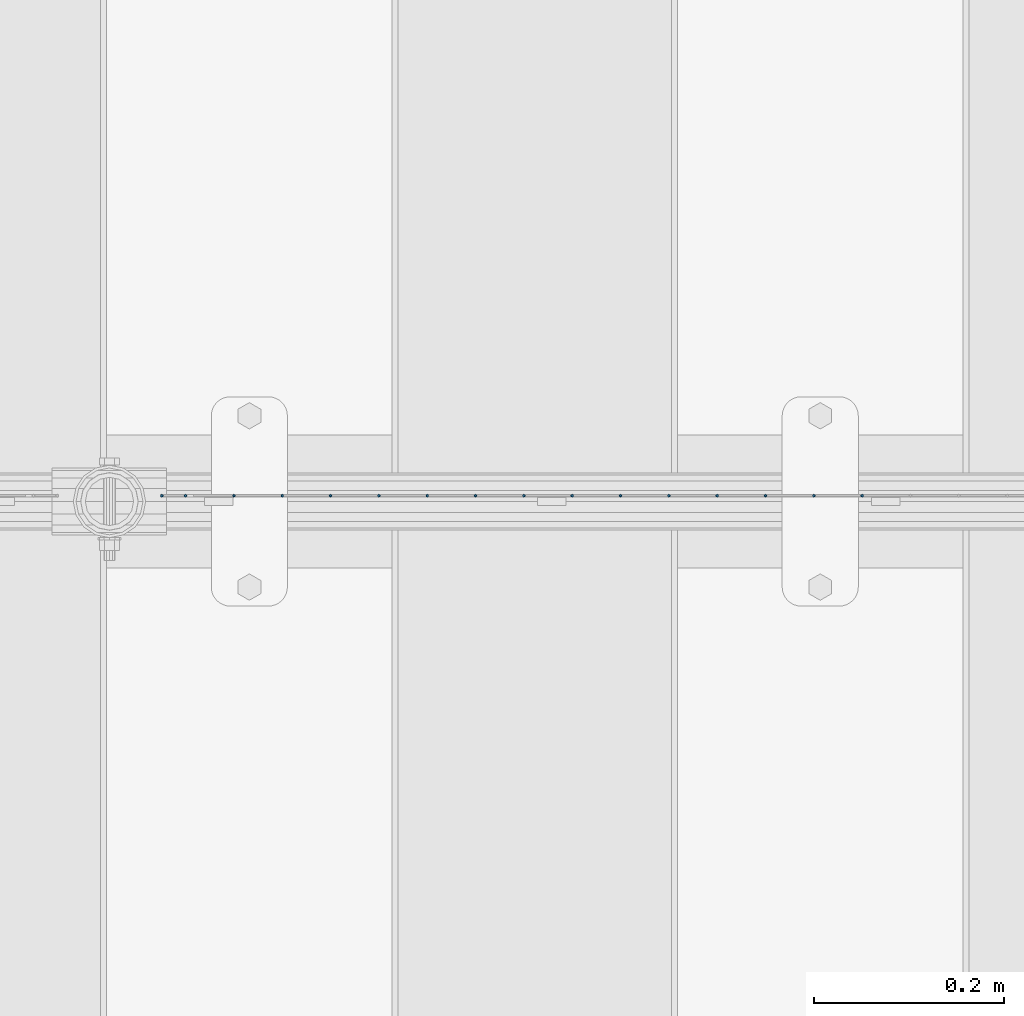
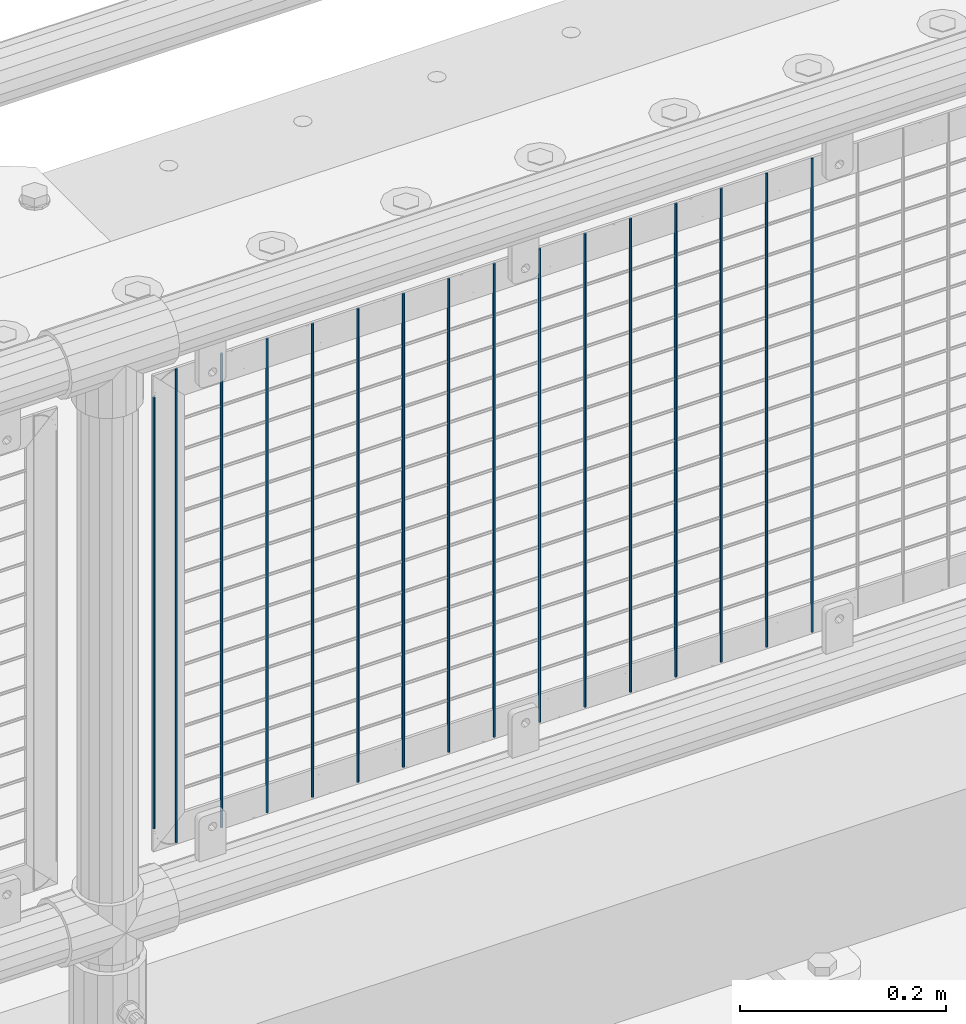
# One storey, part 77 of 242: 16 columns.
"""IFC2X3 building model written with IfcOpenShell, lengths in millimetres."""

from ifc_helpers import new_model, si_unit, frame, origin_with_axes, place, context, subcontext, project, spatial, faceted_brep, material, type_object, element, save


model = new_model("IFC2X3")

# Units and contexts
model_context = context("Model", 3, precision=1e-05, world=origin_with_axes())
body_context = subcontext(model_context, "Body", "Model", "MODEL_VIEW")
ifc_project = project(units=[si_unit("LENGTHUNIT", "METRE", prefix="MILLI"), si_unit("AREAUNIT", "SQUARE_METRE"), si_unit("VOLUMEUNIT", "CUBIC_METRE"), si_unit("MASSUNIT", "GRAM", prefix="KILO"), si_unit("TIMEUNIT", "SECOND"), si_unit("PLANEANGLEUNIT", "RADIAN"), si_unit("SOLIDANGLEUNIT", "STERADIAN"), si_unit("THERMODYNAMICTEMPERATUREUNIT", "DEGREE_CELSIUS"), si_unit("LUMINOUSINTENSITYUNIT", "LUMEN")], contexts=[model_context])

# Site, building, storey
site_placement = place(None, origin_with_axes())
site = spatial("IfcSite", under=ifc_project, at=site_placement, CompositionType="ELEMENT")
building_placement = place(site_placement, origin_with_axes())
building = spatial("IfcBuilding", under=site, at=building_placement, Name="Standard", CompositionType="ELEMENT")
storey_placement = place(building_placement, origin_with_axes())
storey = spatial("IfcBuildingStorey", under=building, at=storey_placement, Name="Undefined", CompositionType="ELEMENT", Elevation=0.0)

# Columns
ifc_material = material(Name="Misc_Undefined")
column_type = type_object("IfcColumnType", Name="D3", PredefinedType="NOTDEFINED")
for number, where, z_axis, x_axis in (
    (1, (-34505.898, -19329.5, 353.02), (-1.0, 0.0, 0.0), (0.0, 0.0, 1.0)),
    (2, (-34556.691, -19329.5, 353.02), (-1.0, 0.0, 0.0), (0.0, 0.0, 1.0)),
    (3, (-34607.484, -19329.5, 353.02), (-1.0, 0.0, 0.0), (0.0, 0.0, 1.0)),
    (4, (-34658.277, -19329.5, 353.02), (-1.0, 0.0, 0.0), (0.0, 0.0, 1.0)),
    (5, (-34709.07, -19329.5, 353.02), (-1.0, 0.0, 0.0), (0.0, 0.0, 1.0)),
    (6, (-34759.863, -19329.5, 353.02), (-1.0, 0.0, 0.0), (0.0, 0.0, 1.0)),
    (7, (-34810.656, -19329.5, 353.02), (-1.0, 0.0, 0.0), (0.0, 0.0, 1.0)),
    (8, (-34861.449, -19329.5, 353.02), (-1.0, 0.0, 0.0), (0.0, 0.0, 1.0)),
    (9, (-34912.242, -19329.5, 353.02), (-1.0, 0.0, 0.0), (0.0, 0.0, 1.0)),
    (10, (-34963.035, -19329.5, 353.02), (-1.0, 0.0, 0.0), (0.0, 0.0, 1.0)),
    (11, (-35013.828, -19329.5, 353.02), (-1.0, 0.0, 0.0), (0.0, 0.0, 1.0)),
    (12, (-35064.621, -19329.5, 353.02), (-1.0, 0.0, 0.0), (0.0, 0.0, 1.0)),
    (13, (-35115.414, -19329.5, 353.02), (-1.0, 0.0, 0.0), (0.0, 0.0, 1.0)),
    (14, (-35166.207, -19329.5, 353.02), (-1.0, 0.0, 0.0), (0.0, 0.0, 1.0)),
):
    element("IfcColumn", number, at=place(storey_placement, frame(where, z_axis=z_axis, x_axis=x_axis)), inside=storey, type_object=column_type, material=ifc_material, ObjectType="D3", context=body_context, shape_type="Brep", body=[
        faceted_brep([(0.0, -1.50000000000364, 0.0), (-3.63797880709171e-12, -0.750000000003638, -1.29903810567669), (560.0, -0.75, -1.29903810567703), (560.0, -1.5, 0.0), (0.0, 0.749999999996362, -1.29903810567669), (560.0, 0.75, -1.29903810567703), (-3.63797880709171e-12, 1.49999999999636, 0.0), (560.0, 1.5, 0.0), (0.0, 0.749999999996362, 1.29903810567669), (560.0, 0.75, 1.29903810567703), (-3.63797880709171e-12, -0.750000000003638, 1.29903810567669), (560.0, -0.75, 1.29903810567703)], [[[0, 1, 2, 3]], [[1, 4, 5, 2]], [[4, 6, 7, 5]], [[6, 8, 9, 7]], [[8, 10, 11, 9]], [[10, 0, 3, 11]], [[5, 7, 9, 11, 3, 2]], [[10, 8, 6, 4, 1, 0]]]),
    ])
column_1_placement = place(storey_placement, frame((-35242.0, -19329.5, 378.02), z_axis=(-1.0, 0.0, 0.0), x_axis=(0.0, 0.0, 1.0)))
element("IfcColumn", 15, at=column_1_placement, inside=storey, type_object=column_type, material=ifc_material, ObjectType="D3", context=body_context, shape_type="Brep", body=[
    faceted_brep([(0.0, -1.50000000000364, 0.0), (-3.63797880709171e-12, -0.750000000003638, -1.29903810567669), (510.0, -0.75, -1.29903810567703), (510.0, -1.5, 0.0), (0.0, 0.749999999996362, -1.29903810567669), (510.0, 0.75, -1.29903810567703), (-3.63797880709171e-12, 1.49999999999636, 0.0), (510.0, 1.5, 0.0), (0.0, 0.749999999996362, 1.29903810567669), (510.0, 0.75, 1.29903810567703), (-3.63797880709171e-12, -0.750000000003638, 1.29903810567669), (510.0, -0.75, 1.29903810567703)], [[[0, 1, 2, 3]], [[1, 4, 5, 2]], [[4, 6, 7, 5]], [[6, 8, 9, 7]], [[8, 10, 11, 9]], [[10, 0, 3, 11]], [[5, 7, 9, 11, 3, 2]], [[10, 8, 6, 4, 1, 0]]]),
])
column_2_placement = place(storey_placement, frame((-35217.0, -19329.5, 353.02), z_axis=(-1.0, 0.0, 0.0), x_axis=(0.0, 0.0, 1.0)))
element("IfcColumn", 16, at=column_2_placement, inside=storey, type_object=column_type, material=ifc_material, ObjectType="D3", context=body_context, shape_type="Brep", body=[
    faceted_brep([(0.0, -1.50000000000364, 0.0), (-3.63797880709171e-12, -0.750000000003638, -1.29903810567669), (560.0, -0.75, -1.29903810567703), (560.0, -1.5, 0.0), (0.0, 0.749999999996362, -1.29903810567669), (560.0, 0.75, -1.29903810567703), (-3.63797880709171e-12, 1.49999999999636, 0.0), (560.0, 1.5, 0.0), (0.0, 0.749999999996362, 1.29903810567669), (560.0, 0.75, 1.29903810567703), (-3.63797880709171e-12, -0.750000000003638, 1.29903810567669), (560.0, -0.75, 1.29903810567703)], [[[0, 1, 2, 3]], [[1, 4, 5, 2]], [[4, 6, 7, 5]], [[6, 8, 9, 7]], [[8, 10, 11, 9]], [[10, 0, 3, 11]], [[5, 7, 9, 11, 3, 2]], [[10, 8, 6, 4, 1, 0]]]),
])

save(model, "model.ifc")
